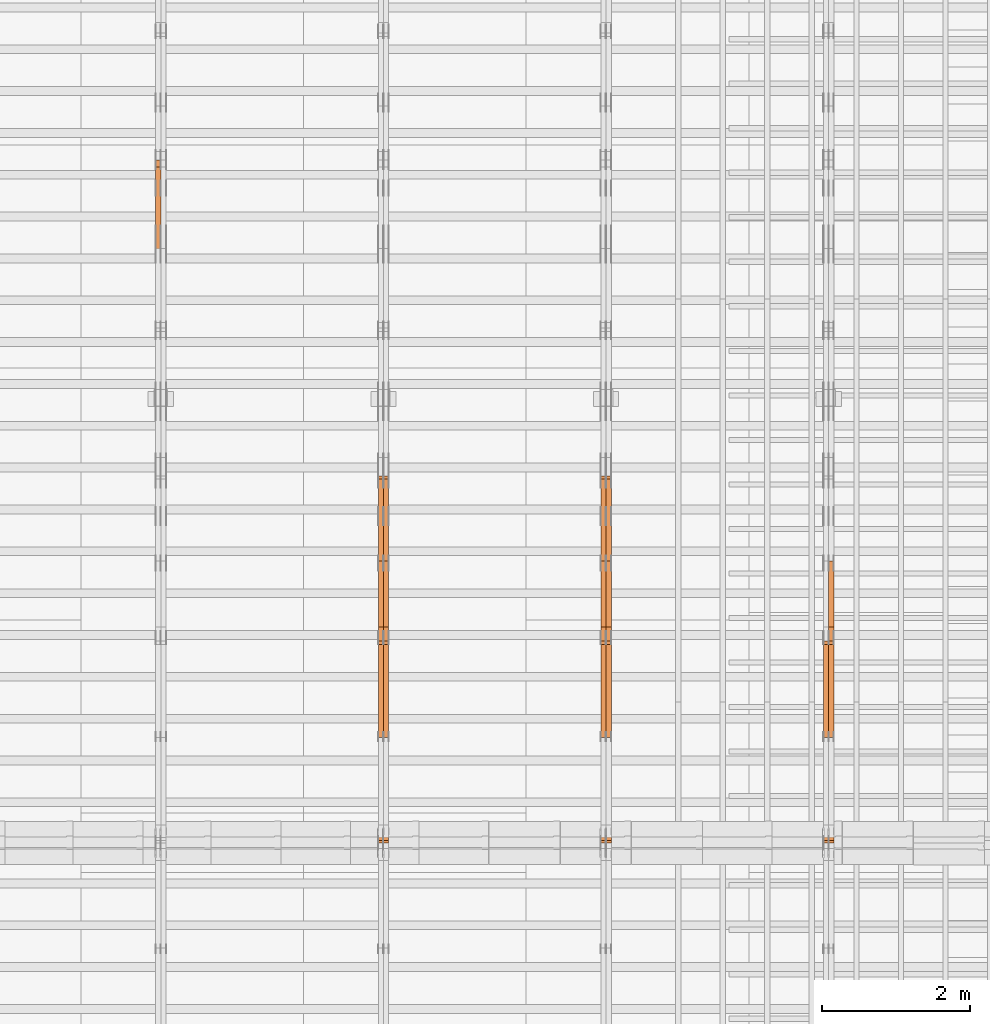
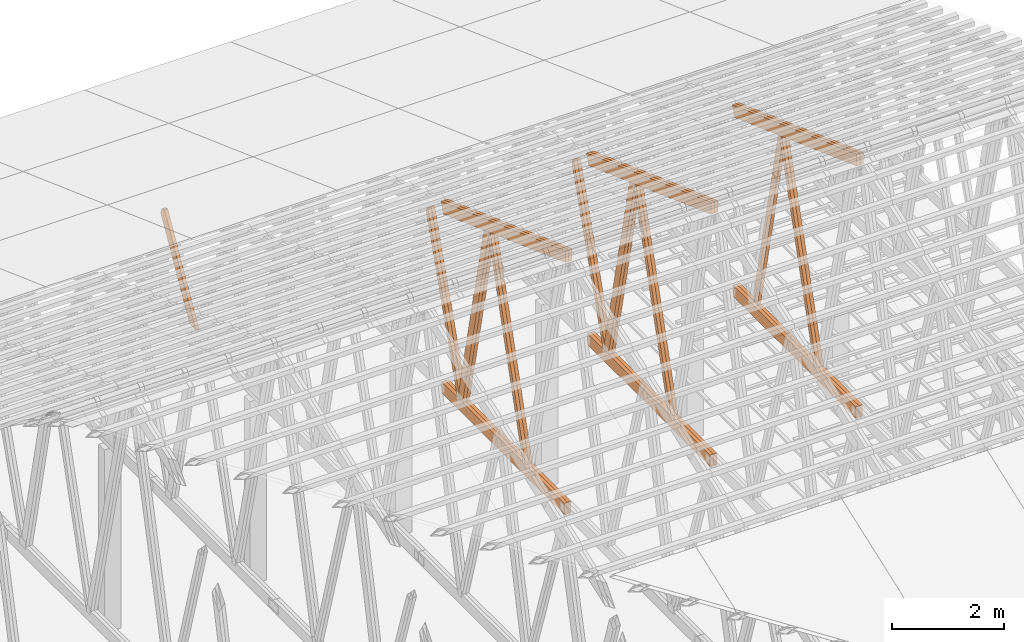
# One storey, part 59 of 189: 28 proxies.
"""IFC2X3 building model written with IfcOpenShell, lengths in millimetres."""

from ifc_helpers import new_model, entity, si_unit, converted_unit, derived_unit, direction, frame, origin, origin_2d_with_axis, place, context, subcontext, project, spatial, polyline, rectangle, outline, extrude, source, transform, mapped, material, type_object, type_shapes, element, save


model = new_model("IFC2X3")

# Units and contexts
model_context = context("Model", 3, precision=0.01, world=origin(), true_north=direction((6.12303176911189e-17, 1.0)))
body_context = subcontext(model_context, "Body", "Model", "MODEL_VIEW")
ifc_project = project(units=[si_unit("LENGTHUNIT", "METRE", prefix="MILLI"), si_unit("AREAUNIT", "SQUARE_METRE"), si_unit("VOLUMEUNIT", "CUBIC_METRE"), converted_unit("PLANEANGLEUNIT", "DEGREE", entity("IfcRatioMeasure", 0.0174532925199433), si_unit("PLANEANGLEUNIT", "RADIAN"), dimensions=[0, 0, 0, 0, 0, 0, 0]), si_unit("MASSUNIT", "GRAM", prefix="KILO"), derived_unit("MASSDENSITYUNIT", [(si_unit("MASSUNIT", "GRAM", prefix="KILO"), 1), (si_unit("LENGTHUNIT", "METRE"), -3)]), si_unit("TIMEUNIT", "SECOND"), si_unit("FREQUENCYUNIT", "HERTZ"), si_unit("THERMODYNAMICTEMPERATUREUNIT", "DEGREE_CELSIUS"), derived_unit("THERMALTRANSMITTANCEUNIT", [(si_unit("MASSUNIT", "GRAM", prefix="KILO"), 1), (si_unit("THERMODYNAMICTEMPERATUREUNIT", "KELVIN"), -1), (si_unit("TIMEUNIT", "SECOND"), -3)]), derived_unit("VOLUMETRICFLOWRATEUNIT", [(si_unit("LENGTHUNIT", "METRE"), 3), (si_unit("TIMEUNIT", "SECOND"), -1)]), si_unit("ELECTRICCURRENTUNIT", "AMPERE"), si_unit("ELECTRICVOLTAGEUNIT", "VOLT"), si_unit("POWERUNIT", "WATT"), si_unit("FORCEUNIT", "NEWTON"), si_unit("ILLUMINANCEUNIT", "LUX"), si_unit("LUMINOUSFLUXUNIT", "LUMEN"), si_unit("LUMINOUSINTENSITYUNIT", "CANDELA"), derived_unit("USERDEFINED", [(si_unit("MASSUNIT", "GRAM", prefix="KILO"), -1), (si_unit("LENGTHUNIT", "METRE"), -2), (si_unit("TIMEUNIT", "SECOND"), 3), (si_unit("LUMINOUSFLUXUNIT", "LUMEN"), 1)]), derived_unit("LINEARVELOCITYUNIT", [(si_unit("LENGTHUNIT", "METRE"), 1), (si_unit("TIMEUNIT", "SECOND"), -1)]), si_unit("PRESSUREUNIT", "PASCAL"), derived_unit("USERDEFINED", [(si_unit("LENGTHUNIT", "METRE"), -2), (si_unit("MASSUNIT", "GRAM", prefix="KILO"), 1), (si_unit("TIMEUNIT", "SECOND"), -2)])], contexts=[model_context])

# Site, building, storey
site_placement = place(None, origin())
site = spatial("IfcSite", under=ifc_project, at=site_placement, CompositionType="ELEMENT")
building_placement = place(site_placement, origin())
building = spatial("IfcBuilding", under=site, at=building_placement, CompositionType="ELEMENT")
storey_placement = place(building_placement, origin())
storey = spatial("IfcBuildingStorey", under=building, at=storey_placement, Name="Default", CompositionType="ELEMENT", Elevation=0.0)

# Proxies
ifc_material_1 = material(Name="IfcSurfaceStyle #241928")
building_element_proxy_type_1 = type_object("IfcBuildingElementProxyType", Name="T1-W6 241926", PredefinedType="NOTDEFINED", material=ifc_material_1)
shared_shape_1 = source(origin(), body_context, "Body", "SweptSolid", [
    extrude(outline(polyline([(-2668.68989660745, -47.5002238228721), (1800.72567700045, -47.5002238228721), (1797.68490303083, 0.000158637170537834), (1711.12272493628, 47.5001445042868), (-2640.84340836012, 47.5001445042868), (-2668.68989660745, -47.5002238228721)])), frame((1800.7257704503, 47.5001445042868, 0.0), z_axis=(0.0, 0.0, 1.0), x_axis=(-1.0, 0.0, 0.0)), (0.0, 0.0, 1.0), 69.9999999999997),
])
type_shapes(building_element_proxy_type_1, [shared_shape_1])
proxy_1_placement = place(building_placement, frame((45300.0, 17516.8749791841, 4507.23620831254), z_axis=(-1.0, 0.0, 0.0), x_axis=(0.0, -0.281285983104611, -0.959623986626466)))
element("IfcBuildingElementProxy", 1, at=proxy_1_placement, inside=storey, type_object=building_element_proxy_type_1, material=ifc_material_1, Name="T1-W6", context=body_context, shape_type="MappedRepresentation", body=[
    mapped(shared_shape_1, transform((0.0, 0.0, 0.0), scale=1.0)),
])
ifc_material_2 = material(Name="IfcSurfaceStyle #241862")
building_element_proxy_type_2 = type_object("IfcBuildingElementProxyType", Name="T1-W6 241860", PredefinedType="NOTDEFINED", material=ifc_material_2)
shared_shape_2 = source(origin(), body_context, "Body", "SweptSolid", [
    extrude(outline(polyline([(-2668.68989660745, -47.5002238228721), (1800.72567700045, -47.5002238228721), (1797.68490303083, 0.000158637170537834), (1711.12272493628, 47.5001445042868), (-2640.84340836012, 47.5001445042868), (-2668.68989660745, -47.5002238228721)])), frame((1800.7257704503, 47.5001445042868, 0.0), z_axis=(0.0, 0.0, 1.0), x_axis=(-1.0, 0.0, 0.0)), (0.0, 0.0, 1.0), 69.9999999999997),
])
type_shapes(building_element_proxy_type_2, [shared_shape_2])
proxy_2_placement = place(building_placement, frame((45230.0, 17516.8749791841, 4507.23620831254), z_axis=(-1.0, 0.0, 0.0), x_axis=(0.0, -0.281285983104611, -0.959623986626466)))
element("IfcBuildingElementProxy", 2, at=proxy_2_placement, inside=storey, type_object=building_element_proxy_type_2, material=ifc_material_2, Name="T1-W6", context=body_context, shape_type="MappedRepresentation", body=[
    mapped(shared_shape_2, transform((0.0, 0.0, 0.0), scale=1.0)),
])
ifc_material_3 = material(Name="IfcSurfaceStyle #241664")
building_element_proxy_type_3 = type_object("IfcBuildingElementProxyType", Name="T1-W3 241662", PredefinedType="NOTDEFINED", material=ifc_material_3)
shared_shape_3 = source(origin(), body_context, "Body", "SweptSolid", [
    extrude(outline(polyline([(-2517.58938959787, -85.0001104675026), (1625.445846867, -85.0001104675027), (1768.20563426494, 0.000209440697654673), (1749.48871563991, 85.0000057471538), (-2625.55080717397, 85.0000057471538), (-2517.58938959787, -85.0001104675026)])), frame((1768.2056683344, 85.0000547211315, 0.0), z_axis=(0.0, 0.0, 1.0), x_axis=(-1.0, 0.0, 0.0)), (0.0, 0.0, 1.0), 69.9999999999997),
])
type_shapes(building_element_proxy_type_3, [shared_shape_3])
proxy_3_placement = place(building_placement, frame((45300.0, 18415.3042863408, 226.720947016584), z_axis=(-1.0, 0.0, 0.0), x_axis=(0.0, -0.215047682154604, 0.976603550269982)))
element("IfcBuildingElementProxy", 3, at=proxy_3_placement, inside=storey, type_object=building_element_proxy_type_3, material=ifc_material_3, Name="T1-W3", context=body_context, shape_type="MappedRepresentation", body=[
    mapped(shared_shape_3, transform((0.0, 0.0, 0.0), scale=1.0)),
])
ifc_material_4 = material(Name="IfcSurfaceStyle #238154")
building_element_proxy_type_4 = type_object("IfcBuildingElementProxyType", Name="T1-B5 238152", PredefinedType="NOTDEFINED", material=ifc_material_4)
shared_shape_4 = source(origin(), body_context, "Body", "SweptSolid", [
    extrude(rectangle(XDim=4381.5, YDim=245.000000000001, at=origin_2d_with_axis()), frame((2190.75, 122.5, 0.0), z_axis=(0.0, 0.0, 1.0), x_axis=(-1.0, 0.0, 0.0)), (0.0, 0.0, 1.0), 69.9999999999997),
])
type_shapes(building_element_proxy_type_4, [shared_shape_4])
proxy_4_placement = place(building_placement, frame((45300.0, 14780.2587890625, 245.0), z_axis=(-1.0, 0.0, 0.0), x_axis=(0.0, 1.0, 0.0)))
element("IfcBuildingElementProxy", 4, at=proxy_4_placement, inside=storey, type_object=building_element_proxy_type_4, material=ifc_material_4, Name="T1-B5", context=body_context, shape_type="MappedRepresentation", body=[
    mapped(shared_shape_4, transform((0.0, 0.0, 0.0), scale=1.0)),
])
ifc_material_5 = material(Name="IfcSurfaceStyle #238097")
building_element_proxy_type_5 = type_object("IfcBuildingElementProxyType", Name="T1-B5 238095", PredefinedType="NOTDEFINED", material=ifc_material_5)
shared_shape_5 = source(origin(), body_context, "Body", "SweptSolid", [
    extrude(rectangle(XDim=4381.5, YDim=245.000000000001, at=origin_2d_with_axis()), frame((2190.75, 122.5, 0.0), z_axis=(0.0, 0.0, 1.0), x_axis=(-1.0, 0.0, 0.0)), (0.0, 0.0, 1.0), 69.9999999999997),
])
type_shapes(building_element_proxy_type_5, [shared_shape_5])
proxy_5_placement = place(building_placement, frame((45230.0, 14780.2587890625, 245.0), z_axis=(-1.0, 0.0, 0.0), x_axis=(0.0, 1.0, 0.0)))
element("IfcBuildingElementProxy", 5, at=proxy_5_placement, inside=storey, type_object=building_element_proxy_type_5, material=ifc_material_5, Name="T1-B5", context=body_context, shape_type="MappedRepresentation", body=[
    mapped(shared_shape_5, transform((0.0, 0.0, 0.0), scale=1.0)),
])
ifc_material_6 = material(Name="IfcSurfaceStyle #237338")
building_element_proxy_type_6 = type_object("IfcBuildingElementProxyType", Name="T1-T3 237336", PredefinedType="NOTDEFINED", material=ifc_material_6)
shared_shape_6 = source(origin(), body_context, "Body", "SweptSolid", [
    extrude(outline(polyline([(-2386.23525922045, -122.500022994835), (2341.64890001386, -122.500022994835), (2341.64888416412, 122.500022994835), (-2297.06252495753, 122.500022994835), (-2386.23525922045, -122.500022994835)])), frame((2341.64890001386, 122.500051926629, 0.0), z_axis=(0.0, 0.0, 1.0), x_axis=(-1.0, 0.0, 0.0)), (0.0, 0.0, 1.0), 69.9999999999997),
])
type_shapes(building_element_proxy_type_6, [shared_shape_6])
proxy_6_placement = place(building_placement, frame((45300.0, 19108.9628956236, 3921.30465489208), z_axis=(-1.0, 0.0, 0.0), x_axis=(0.0, -0.939692620785908, 0.342020143325669)))
element("IfcBuildingElementProxy", 6, at=proxy_6_placement, inside=storey, type_object=building_element_proxy_type_6, material=ifc_material_6, Name="T1-T3", context=body_context, shape_type="MappedRepresentation", body=[
    mapped(shared_shape_6, transform((0.0, 0.0, 0.0), scale=1.0)),
])
ifc_material_7 = material(Name="IfcSurfaceStyle #237281")
building_element_proxy_type_7 = type_object("IfcBuildingElementProxyType", Name="T1-T3 237279", PredefinedType="NOTDEFINED", material=ifc_material_7)
shared_shape_7 = source(origin(), body_context, "Body", "SweptSolid", [
    extrude(outline(polyline([(-2386.23525922045, -122.500022994835), (2341.64890001386, -122.500022994835), (2341.64888416412, 122.500022994835), (-2297.06252495753, 122.500022994835), (-2386.23525922045, -122.500022994835)])), frame((2341.64890001386, 122.500051926629, 0.0), z_axis=(0.0, 0.0, 1.0), x_axis=(-1.0, 0.0, 0.0)), (0.0, 0.0, 1.0), 69.9999999999997),
])
type_shapes(building_element_proxy_type_7, [shared_shape_7])
proxy_7_placement = place(building_placement, frame((45230.0, 19108.9628956236, 3921.30465489208), z_axis=(-1.0, 0.0, 0.0), x_axis=(0.0, -0.939692620785908, 0.342020143325669)))
element("IfcBuildingElementProxy", 7, at=proxy_7_placement, inside=storey, type_object=building_element_proxy_type_7, material=ifc_material_7, Name="T1-T3", context=body_context, shape_type="MappedRepresentation", body=[
    mapped(shared_shape_7, transform((0.0, 0.0, 0.0), scale=1.0)),
])
ifc_material_8 = material(Name="IfcSurfaceStyle #226138")
building_element_proxy_type_8 = type_object("IfcBuildingElementProxyType", Name="T1-W6 226136", PredefinedType="NOTDEFINED", material=ifc_material_8)
shared_shape_8 = source(origin(), body_context, "Body", "SweptSolid", [
    extrude(outline(polyline([(-2668.68989660745, -47.5002238228721), (1800.72567700045, -47.5002238228721), (1797.68490303083, 0.000158637170537834), (1711.12272493628, 47.5001445042868), (-2640.84340836012, 47.5001445042868), (-2668.68989660745, -47.5002238228721)])), frame((1800.7257704503, 47.5001445042868, 0.0), z_axis=(0.0, 0.0, 1.0), x_axis=(-1.0, 0.0, 0.0)), (0.0, 0.0, 1.0), 69.9999999999997),
])
type_shapes(building_element_proxy_type_8, [shared_shape_8])
proxy_8_placement = place(building_placement, frame((42300.0, 17516.8749791841, 4507.23620831254), z_axis=(-1.0, 0.0, 0.0), x_axis=(0.0, -0.281285983104611, -0.959623986626466)))
element("IfcBuildingElementProxy", 8, at=proxy_8_placement, inside=storey, type_object=building_element_proxy_type_8, material=ifc_material_8, Name="T1-W6", context=body_context, shape_type="MappedRepresentation", body=[
    mapped(shared_shape_8, transform((0.0, 0.0, 0.0), scale=1.0)),
])
ifc_material_9 = material(Name="IfcSurfaceStyle #226072")
building_element_proxy_type_9 = type_object("IfcBuildingElementProxyType", Name="T1-W6 226070", PredefinedType="NOTDEFINED", material=ifc_material_9)
shared_shape_9 = source(origin(), body_context, "Body", "SweptSolid", [
    extrude(outline(polyline([(-2668.68989660745, -47.5002238228721), (1800.72567700045, -47.5002238228721), (1797.68490303083, 0.000158637170537834), (1711.12272493628, 47.5001445042868), (-2640.84340836012, 47.5001445042868), (-2668.68989660745, -47.5002238228721)])), frame((1800.7257704503, 47.5001445042868, 0.0), z_axis=(0.0, 0.0, 1.0), x_axis=(-1.0, 0.0, 0.0)), (0.0, 0.0, 1.0), 69.9999999999997),
])
type_shapes(building_element_proxy_type_9, [shared_shape_9])
proxy_9_placement = place(building_placement, frame((42230.0, 17516.8749791841, 4507.23620831254), z_axis=(-1.0, 0.0, 0.0), x_axis=(0.0, -0.281285983104611, -0.959623986626466)))
element("IfcBuildingElementProxy", 9, at=proxy_9_placement, inside=storey, type_object=building_element_proxy_type_9, material=ifc_material_9, Name="T1-W6", context=body_context, shape_type="MappedRepresentation", body=[
    mapped(shared_shape_9, transform((0.0, 0.0, 0.0), scale=1.0)),
])
ifc_material_10 = material(Name="IfcSurfaceStyle #225874")
building_element_proxy_type_10 = type_object("IfcBuildingElementProxyType", Name="T1-W3 225872", PredefinedType="NOTDEFINED", material=ifc_material_10)
shared_shape_10 = source(origin(), body_context, "Body", "SweptSolid", [
    extrude(outline(polyline([(-2517.58938959787, -85.0001104675026), (1625.445846867, -85.0001104675027), (1768.20563426494, 0.000209440697654673), (1749.48871563991, 85.0000057471538), (-2625.55080717397, 85.0000057471538), (-2517.58938959787, -85.0001104675026)])), frame((1768.2056683344, 85.0000547211315, 0.0), z_axis=(0.0, 0.0, 1.0), x_axis=(-1.0, 0.0, 0.0)), (0.0, 0.0, 1.0), 69.9999999999997),
])
type_shapes(building_element_proxy_type_10, [shared_shape_10])
proxy_10_placement = place(building_placement, frame((42300.0, 18415.3042863408, 226.720947016584), z_axis=(-1.0, 0.0, 0.0), x_axis=(0.0, -0.215047682154604, 0.976603550269982)))
element("IfcBuildingElementProxy", 10, at=proxy_10_placement, inside=storey, type_object=building_element_proxy_type_10, material=ifc_material_10, Name="T1-W3", context=body_context, shape_type="MappedRepresentation", body=[
    mapped(shared_shape_10, transform((0.0, 0.0, 0.0), scale=1.0)),
])
ifc_material_11 = material(Name="IfcSurfaceStyle #225808")
building_element_proxy_type_11 = type_object("IfcBuildingElementProxyType", Name="T1-W3 225806", PredefinedType="NOTDEFINED", material=ifc_material_11)
shared_shape_11 = source(origin(), body_context, "Body", "SweptSolid", [
    extrude(outline(polyline([(-2517.58938959787, -85.0001104675026), (1625.445846867, -85.0001104675027), (1768.20563426494, 0.000209440697654673), (1749.48871563991, 85.0000057471538), (-2625.55080717397, 85.0000057471538), (-2517.58938959787, -85.0001104675026)])), frame((1768.2056683344, 85.0000547211315, 0.0), z_axis=(0.0, 0.0, 1.0), x_axis=(-1.0, 0.0, 0.0)), (0.0, 0.0, 1.0), 69.9999999999997),
])
type_shapes(building_element_proxy_type_11, [shared_shape_11])
proxy_11_placement = place(building_placement, frame((42230.0, 18415.3042863408, 226.720947016584), z_axis=(-1.0, 0.0, 0.0), x_axis=(0.0, -0.215047682154604, 0.976603550269982)))
element("IfcBuildingElementProxy", 11, at=proxy_11_placement, inside=storey, type_object=building_element_proxy_type_11, material=ifc_material_11, Name="T1-W3", context=body_context, shape_type="MappedRepresentation", body=[
    mapped(shared_shape_11, transform((0.0, 0.0, 0.0), scale=1.0)),
])
ifc_material_12 = material(Name="IfcSurfaceStyle #225610")
building_element_proxy_type_12 = type_object("IfcBuildingElementProxyType", Name="T1-W7 225608", PredefinedType="NOTDEFINED", material=ifc_material_12)
shared_shape_12 = source(origin(), body_context, "Body", "SweptSolid", [
    extrude(outline(polyline([(-2189.6662270939, -47.5000140805343), (1475.30081553583, -47.5000140805343), (1473.93388518462, 0.00042343352179337), (1398.58463533215, 47.4998023637734), (-2158.15310895869, 47.4998023637734), (-2189.6662270939, -47.5000140805343)])), frame((1475.30081553583, 47.5004895824757, 0.0), z_axis=(0.0, 0.0, 1.0), x_axis=(-1.0, 0.0, 0.0)), (0.0, 0.0, 1.0), 69.9999999999998),
])
type_shapes(building_element_proxy_type_12, [shared_shape_12])
proxy_12_placement = place(building_placement, frame((42300.0, 19742.3819153401, 3693.66743808885), z_axis=(-1.0, 0.0, 0.0), x_axis=(0.0, -0.314845237923104, -0.949143021971475)))
element("IfcBuildingElementProxy", 12, at=proxy_12_placement, inside=storey, type_object=building_element_proxy_type_12, material=ifc_material_12, Name="T1-W7", context=body_context, shape_type="MappedRepresentation", body=[
    mapped(shared_shape_12, transform((0.0, 0.0, 0.0), scale=1.0)),
])
ifc_material_13 = material(Name="IfcSurfaceStyle #225544")
building_element_proxy_type_13 = type_object("IfcBuildingElementProxyType", Name="T1-W7 225542", PredefinedType="NOTDEFINED", material=ifc_material_13)
shared_shape_13 = source(origin(), body_context, "Body", "SweptSolid", [
    extrude(outline(polyline([(-2189.6662270939, -47.5000140805343), (1475.30081553583, -47.5000140805343), (1473.93388518462, 0.00042343352179337), (1398.58463533215, 47.4998023637734), (-2158.15310895869, 47.4998023637734), (-2189.6662270939, -47.5000140805343)])), frame((1475.30081553583, 47.5004895824757, 0.0), z_axis=(0.0, 0.0, 1.0), x_axis=(-1.0, 0.0, 0.0)), (0.0, 0.0, 1.0), 69.9999999999998),
])
type_shapes(building_element_proxy_type_13, [shared_shape_13])
proxy_13_placement = place(building_placement, frame((42230.0, 19742.3819153401, 3693.66743808885), z_axis=(-1.0, 0.0, 0.0), x_axis=(0.0, -0.314845237923104, -0.949143021971475)))
element("IfcBuildingElementProxy", 13, at=proxy_13_placement, inside=storey, type_object=building_element_proxy_type_13, material=ifc_material_13, Name="T1-W7", context=body_context, shape_type="MappedRepresentation", body=[
    mapped(shared_shape_13, transform((0.0, 0.0, 0.0), scale=1.0)),
])
ifc_material_14 = material(Name="IfcSurfaceStyle #222364")
building_element_proxy_type_14 = type_object("IfcBuildingElementProxyType", Name="T1-B5 222362", PredefinedType="NOTDEFINED", material=ifc_material_14)
shared_shape_14 = source(origin(), body_context, "Body", "SweptSolid", [
    extrude(rectangle(XDim=4381.5, YDim=245.000000000001, at=origin_2d_with_axis()), frame((2190.75, 122.5, 0.0), z_axis=(0.0, 0.0, 1.0), x_axis=(-1.0, 0.0, 0.0)), (0.0, 0.0, 1.0), 69.9999999999997),
])
type_shapes(building_element_proxy_type_14, [shared_shape_14])
proxy_14_placement = place(building_placement, frame((42300.0, 14780.2587890625, 245.0), z_axis=(-1.0, 0.0, 0.0), x_axis=(0.0, 1.0, 0.0)))
element("IfcBuildingElementProxy", 14, at=proxy_14_placement, inside=storey, type_object=building_element_proxy_type_14, material=ifc_material_14, Name="T1-B5", context=body_context, shape_type="MappedRepresentation", body=[
    mapped(shared_shape_14, transform((0.0, 0.0, 0.0), scale=1.0)),
])
ifc_material_15 = material(Name="IfcSurfaceStyle #222307")
building_element_proxy_type_15 = type_object("IfcBuildingElementProxyType", Name="T1-B5 222305", PredefinedType="NOTDEFINED", material=ifc_material_15)
shared_shape_15 = source(origin(), body_context, "Body", "SweptSolid", [
    extrude(rectangle(XDim=4381.5, YDim=245.000000000001, at=origin_2d_with_axis()), frame((2190.75, 122.5, 0.0), z_axis=(0.0, 0.0, 1.0), x_axis=(-1.0, 0.0, 0.0)), (0.0, 0.0, 1.0), 69.9999999999997),
])
type_shapes(building_element_proxy_type_15, [shared_shape_15])
proxy_15_placement = place(building_placement, frame((42230.0, 14780.2587890625, 245.0), z_axis=(-1.0, 0.0, 0.0), x_axis=(0.0, 1.0, 0.0)))
element("IfcBuildingElementProxy", 15, at=proxy_15_placement, inside=storey, type_object=building_element_proxy_type_15, material=ifc_material_15, Name="T1-B5", context=body_context, shape_type="MappedRepresentation", body=[
    mapped(shared_shape_15, transform((0.0, 0.0, 0.0), scale=1.0)),
])
ifc_material_16 = material(Name="IfcSurfaceStyle #221548")
building_element_proxy_type_16 = type_object("IfcBuildingElementProxyType", Name="T1-T3 221546", PredefinedType="NOTDEFINED", material=ifc_material_16)
shared_shape_16 = source(origin(), body_context, "Body", "SweptSolid", [
    extrude(outline(polyline([(-2386.23525922045, -122.500022994835), (2341.64890001386, -122.500022994835), (2341.64888416412, 122.500022994835), (-2297.06252495753, 122.500022994835), (-2386.23525922045, -122.500022994835)])), frame((2341.64890001386, 122.500051926629, 0.0), z_axis=(0.0, 0.0, 1.0), x_axis=(-1.0, 0.0, 0.0)), (0.0, 0.0, 1.0), 69.9999999999997),
])
type_shapes(building_element_proxy_type_16, [shared_shape_16])
proxy_16_placement = place(building_placement, frame((42300.0, 19108.9628956236, 3921.30465489208), z_axis=(-1.0, 0.0, 0.0), x_axis=(0.0, -0.939692620785908, 0.342020143325669)))
element("IfcBuildingElementProxy", 16, at=proxy_16_placement, inside=storey, type_object=building_element_proxy_type_16, material=ifc_material_16, Name="T1-T3", context=body_context, shape_type="MappedRepresentation", body=[
    mapped(shared_shape_16, transform((0.0, 0.0, 0.0), scale=1.0)),
])
ifc_material_17 = material(Name="IfcSurfaceStyle #221491")
building_element_proxy_type_17 = type_object("IfcBuildingElementProxyType", Name="T1-T3 221489", PredefinedType="NOTDEFINED", material=ifc_material_17)
shared_shape_17 = source(origin(), body_context, "Body", "SweptSolid", [
    extrude(outline(polyline([(-2386.23525922045, -122.500022994835), (2341.64890001386, -122.500022994835), (2341.64888416412, 122.500022994835), (-2297.06252495753, 122.500022994835), (-2386.23525922045, -122.500022994835)])), frame((2341.64890001386, 122.500051926629, 0.0), z_axis=(0.0, 0.0, 1.0), x_axis=(-1.0, 0.0, 0.0)), (0.0, 0.0, 1.0), 69.9999999999997),
])
type_shapes(building_element_proxy_type_17, [shared_shape_17])
proxy_17_placement = place(building_placement, frame((42230.0, 19108.9628956236, 3921.30465489208), z_axis=(-1.0, 0.0, 0.0), x_axis=(0.0, -0.939692620785908, 0.342020143325669)))
element("IfcBuildingElementProxy", 17, at=proxy_17_placement, inside=storey, type_object=building_element_proxy_type_17, material=ifc_material_17, Name="T1-T3", context=body_context, shape_type="MappedRepresentation", body=[
    mapped(shared_shape_17, transform((0.0, 0.0, 0.0), scale=1.0)),
])
ifc_material_18 = material(Name="IfcSurfaceStyle #210348")
building_element_proxy_type_18 = type_object("IfcBuildingElementProxyType", Name="T1-W6 210346", PredefinedType="NOTDEFINED", material=ifc_material_18)
shared_shape_18 = source(origin(), body_context, "Body", "SweptSolid", [
    extrude(outline(polyline([(-2668.68989660745, -47.5002238228721), (1800.72567700045, -47.5002238228721), (1797.68490303083, 0.000158637170537834), (1711.12272493628, 47.5001445042868), (-2640.84340836012, 47.5001445042868), (-2668.68989660745, -47.5002238228721)])), frame((1800.7257704503, 47.5001445042868, 0.0), z_axis=(0.0, 0.0, 1.0), x_axis=(-1.0, 0.0, 0.0)), (0.0, 0.0, 1.0), 69.9999999999997),
])
type_shapes(building_element_proxy_type_18, [shared_shape_18])
proxy_18_placement = place(building_placement, frame((39300.0, 17516.8749791841, 4507.23620831254), z_axis=(-1.0, 0.0, 0.0), x_axis=(0.0, -0.281285983104611, -0.959623986626466)))
element("IfcBuildingElementProxy", 18, at=proxy_18_placement, inside=storey, type_object=building_element_proxy_type_18, material=ifc_material_18, Name="T1-W6", context=body_context, shape_type="MappedRepresentation", body=[
    mapped(shared_shape_18, transform((0.0, 0.0, 0.0), scale=1.0)),
])
ifc_material_19 = material(Name="IfcSurfaceStyle #210282")
building_element_proxy_type_19 = type_object("IfcBuildingElementProxyType", Name="T1-W6 210280", PredefinedType="NOTDEFINED", material=ifc_material_19)
shared_shape_19 = source(origin(), body_context, "Body", "SweptSolid", [
    extrude(outline(polyline([(-2668.68989660745, -47.5002238228721), (1800.72567700045, -47.5002238228721), (1797.68490303083, 0.000158637170537834), (1711.12272493628, 47.5001445042868), (-2640.84340836012, 47.5001445042868), (-2668.68989660745, -47.5002238228721)])), frame((1800.7257704503, 47.5001445042868, 0.0), z_axis=(0.0, 0.0, 1.0), x_axis=(-1.0, 0.0, 0.0)), (0.0, 0.0, 1.0), 69.9999999999997),
])
type_shapes(building_element_proxy_type_19, [shared_shape_19])
proxy_19_placement = place(building_placement, frame((39230.0, 17516.8749791841, 4507.23620831254), z_axis=(-1.0, 0.0, 0.0), x_axis=(0.0, -0.281285983104611, -0.959623986626466)))
element("IfcBuildingElementProxy", 19, at=proxy_19_placement, inside=storey, type_object=building_element_proxy_type_19, material=ifc_material_19, Name="T1-W6", context=body_context, shape_type="MappedRepresentation", body=[
    mapped(shared_shape_19, transform((0.0, 0.0, 0.0), scale=1.0)),
])
ifc_material_20 = material(Name="IfcSurfaceStyle #210084")
building_element_proxy_type_20 = type_object("IfcBuildingElementProxyType", Name="T1-W3 210082", PredefinedType="NOTDEFINED", material=ifc_material_20)
shared_shape_20 = source(origin(), body_context, "Body", "SweptSolid", [
    extrude(outline(polyline([(-2517.58938959787, -85.0001104675026), (1625.445846867, -85.0001104675027), (1768.20563426494, 0.000209440697654673), (1749.48871563991, 85.0000057471538), (-2625.55080717397, 85.0000057471538), (-2517.58938959787, -85.0001104675026)])), frame((1768.2056683344, 85.0000547211315, 0.0), z_axis=(0.0, 0.0, 1.0), x_axis=(-1.0, 0.0, 0.0)), (0.0, 0.0, 1.0), 69.9999999999997),
])
type_shapes(building_element_proxy_type_20, [shared_shape_20])
proxy_20_placement = place(building_placement, frame((39300.0, 18415.3042863408, 226.720947016584), z_axis=(-1.0, 0.0, 0.0), x_axis=(0.0, -0.215047682154604, 0.976603550269982)))
element("IfcBuildingElementProxy", 20, at=proxy_20_placement, inside=storey, type_object=building_element_proxy_type_20, material=ifc_material_20, Name="T1-W3", context=body_context, shape_type="MappedRepresentation", body=[
    mapped(shared_shape_20, transform((0.0, 0.0, 0.0), scale=1.0)),
])
ifc_material_21 = material(Name="IfcSurfaceStyle #210018")
building_element_proxy_type_21 = type_object("IfcBuildingElementProxyType", Name="T1-W3 210016", PredefinedType="NOTDEFINED", material=ifc_material_21)
shared_shape_21 = source(origin(), body_context, "Body", "SweptSolid", [
    extrude(outline(polyline([(-2517.58938959787, -85.0001104675026), (1625.445846867, -85.0001104675027), (1768.20563426494, 0.000209440697654673), (1749.48871563991, 85.0000057471538), (-2625.55080717397, 85.0000057471538), (-2517.58938959787, -85.0001104675026)])), frame((1768.2056683344, 85.0000547211315, 0.0), z_axis=(0.0, 0.0, 1.0), x_axis=(-1.0, 0.0, 0.0)), (0.0, 0.0, 1.0), 69.9999999999997),
])
type_shapes(building_element_proxy_type_21, [shared_shape_21])
proxy_21_placement = place(building_placement, frame((39230.0, 18415.3042863408, 226.720947016584), z_axis=(-1.0, 0.0, 0.0), x_axis=(0.0, -0.215047682154604, 0.976603550269982)))
element("IfcBuildingElementProxy", 21, at=proxy_21_placement, inside=storey, type_object=building_element_proxy_type_21, material=ifc_material_21, Name="T1-W3", context=body_context, shape_type="MappedRepresentation", body=[
    mapped(shared_shape_21, transform((0.0, 0.0, 0.0), scale=1.0)),
])
ifc_material_22 = material(Name="IfcSurfaceStyle #209820")
building_element_proxy_type_22 = type_object("IfcBuildingElementProxyType", Name="T1-W7 209818", PredefinedType="NOTDEFINED", material=ifc_material_22)
shared_shape_22 = source(origin(), body_context, "Body", "SweptSolid", [
    extrude(outline(polyline([(-2189.6662270939, -47.5000140805343), (1475.30081553583, -47.5000140805343), (1473.93388518462, 0.00042343352179337), (1398.58463533215, 47.4998023637734), (-2158.15310895869, 47.4998023637734), (-2189.6662270939, -47.5000140805343)])), frame((1475.30081553583, 47.5004895824757, 0.0), z_axis=(0.0, 0.0, 1.0), x_axis=(-1.0, 0.0, 0.0)), (0.0, 0.0, 1.0), 69.9999999999998),
])
type_shapes(building_element_proxy_type_22, [shared_shape_22])
proxy_22_placement = place(building_placement, frame((39300.0, 19742.3819153401, 3693.66743808885), z_axis=(-1.0, 0.0, 0.0), x_axis=(0.0, -0.314845237923104, -0.949143021971475)))
element("IfcBuildingElementProxy", 22, at=proxy_22_placement, inside=storey, type_object=building_element_proxy_type_22, material=ifc_material_22, Name="T1-W7", context=body_context, shape_type="MappedRepresentation", body=[
    mapped(shared_shape_22, transform((0.0, 0.0, 0.0), scale=1.0)),
])
ifc_material_23 = material(Name="IfcSurfaceStyle #209754")
building_element_proxy_type_23 = type_object("IfcBuildingElementProxyType", Name="T1-W7 209752", PredefinedType="NOTDEFINED", material=ifc_material_23)
shared_shape_23 = source(origin(), body_context, "Body", "SweptSolid", [
    extrude(outline(polyline([(-2189.6662270939, -47.5000140805343), (1475.30081553583, -47.5000140805343), (1473.93388518462, 0.00042343352179337), (1398.58463533215, 47.4998023637734), (-2158.15310895869, 47.4998023637734), (-2189.6662270939, -47.5000140805343)])), frame((1475.30081553583, 47.5004895824757, 0.0), z_axis=(0.0, 0.0, 1.0), x_axis=(-1.0, 0.0, 0.0)), (0.0, 0.0, 1.0), 69.9999999999998),
])
type_shapes(building_element_proxy_type_23, [shared_shape_23])
proxy_23_placement = place(building_placement, frame((39230.0, 19742.3819153401, 3693.66743808885), z_axis=(-1.0, 0.0, 0.0), x_axis=(0.0, -0.314845237923104, -0.949143021971475)))
element("IfcBuildingElementProxy", 23, at=proxy_23_placement, inside=storey, type_object=building_element_proxy_type_23, material=ifc_material_23, Name="T1-W7", context=body_context, shape_type="MappedRepresentation", body=[
    mapped(shared_shape_23, transform((0.0, 0.0, 0.0), scale=1.0)),
])
ifc_material_24 = material(Name="IfcSurfaceStyle #206574")
building_element_proxy_type_24 = type_object("IfcBuildingElementProxyType", Name="T1-B5 206572", PredefinedType="NOTDEFINED", material=ifc_material_24)
shared_shape_24 = source(origin(), body_context, "Body", "SweptSolid", [
    extrude(rectangle(XDim=4381.5, YDim=245.000000000001, at=origin_2d_with_axis()), frame((2190.75, 122.5, 0.0), z_axis=(0.0, 0.0, 1.0), x_axis=(-1.0, 0.0, 0.0)), (0.0, 0.0, 1.0), 69.9999999999997),
])
type_shapes(building_element_proxy_type_24, [shared_shape_24])
proxy_24_placement = place(building_placement, frame((39300.0, 14780.2587890625, 245.0), z_axis=(-1.0, 0.0, 0.0), x_axis=(0.0, 1.0, 0.0)))
element("IfcBuildingElementProxy", 24, at=proxy_24_placement, inside=storey, type_object=building_element_proxy_type_24, material=ifc_material_24, Name="T1-B5", context=body_context, shape_type="MappedRepresentation", body=[
    mapped(shared_shape_24, transform((0.0, 0.0, 0.0), scale=1.0)),
])
ifc_material_25 = material(Name="IfcSurfaceStyle #206517")
building_element_proxy_type_25 = type_object("IfcBuildingElementProxyType", Name="T1-B5 206515", PredefinedType="NOTDEFINED", material=ifc_material_25)
shared_shape_25 = source(origin(), body_context, "Body", "SweptSolid", [
    extrude(rectangle(XDim=4381.5, YDim=245.000000000001, at=origin_2d_with_axis()), frame((2190.75, 122.5, 0.0), z_axis=(0.0, 0.0, 1.0), x_axis=(-1.0, 0.0, 0.0)), (0.0, 0.0, 1.0), 69.9999999999997),
])
type_shapes(building_element_proxy_type_25, [shared_shape_25])
proxy_25_placement = place(building_placement, frame((39230.0, 14780.2587890625, 245.0), z_axis=(-1.0, 0.0, 0.0), x_axis=(0.0, 1.0, 0.0)))
element("IfcBuildingElementProxy", 25, at=proxy_25_placement, inside=storey, type_object=building_element_proxy_type_25, material=ifc_material_25, Name="T1-B5", context=body_context, shape_type="MappedRepresentation", body=[
    mapped(shared_shape_25, transform((0.0, 0.0, 0.0), scale=1.0)),
])
ifc_material_26 = material(Name="IfcSurfaceStyle #205758")
building_element_proxy_type_26 = type_object("IfcBuildingElementProxyType", Name="T1-T3 205756", PredefinedType="NOTDEFINED", material=ifc_material_26)
shared_shape_26 = source(origin(), body_context, "Body", "SweptSolid", [
    extrude(outline(polyline([(-2386.23525922045, -122.500022994835), (2341.64890001386, -122.500022994835), (2341.64888416412, 122.500022994835), (-2297.06252495753, 122.500022994835), (-2386.23525922045, -122.500022994835)])), frame((2341.64890001386, 122.500051926629, 0.0), z_axis=(0.0, 0.0, 1.0), x_axis=(-1.0, 0.0, 0.0)), (0.0, 0.0, 1.0), 69.9999999999997),
])
type_shapes(building_element_proxy_type_26, [shared_shape_26])
proxy_26_placement = place(building_placement, frame((39300.0, 19108.9628956236, 3921.30465489208), z_axis=(-1.0, 0.0, 0.0), x_axis=(0.0, -0.939692620785908, 0.342020143325669)))
element("IfcBuildingElementProxy", 26, at=proxy_26_placement, inside=storey, type_object=building_element_proxy_type_26, material=ifc_material_26, Name="T1-T3", context=body_context, shape_type="MappedRepresentation", body=[
    mapped(shared_shape_26, transform((0.0, 0.0, 0.0), scale=1.0)),
])
ifc_material_27 = material(Name="IfcSurfaceStyle #205701")
building_element_proxy_type_27 = type_object("IfcBuildingElementProxyType", Name="T1-T3 205699", PredefinedType="NOTDEFINED", material=ifc_material_27)
shared_shape_27 = source(origin(), body_context, "Body", "SweptSolid", [
    extrude(outline(polyline([(-2386.23525922045, -122.500022994835), (2341.64890001386, -122.500022994835), (2341.64888416412, 122.500022994835), (-2297.06252495753, 122.500022994835), (-2386.23525922045, -122.500022994835)])), frame((2341.64890001386, 122.500051926629, 0.0), z_axis=(0.0, 0.0, 1.0), x_axis=(-1.0, 0.0, 0.0)), (0.0, 0.0, 1.0), 69.9999999999997),
])
type_shapes(building_element_proxy_type_27, [shared_shape_27])
proxy_27_placement = place(building_placement, frame((39230.0, 19108.9628956236, 3921.30465489208), z_axis=(-1.0, 0.0, 0.0), x_axis=(0.0, -0.939692620785908, 0.342020143325669)))
element("IfcBuildingElementProxy", 27, at=proxy_27_placement, inside=storey, type_object=building_element_proxy_type_27, material=ifc_material_27, Name="T1-T3", context=body_context, shape_type="MappedRepresentation", body=[
    mapped(shared_shape_27, transform((0.0, 0.0, 0.0), scale=1.0)),
])
ifc_material_28 = material(Name="IfcSurfaceStyle #192908")
building_element_proxy_type_28 = type_object("IfcBuildingElementProxyType", Name="T1-W2 192906", PredefinedType="NOTDEFINED", material=ifc_material_28)
shared_shape_28 = source(origin(), body_context, "Body", "SweptSolid", [
    extrude(outline(polyline([(-1361.89144606429, -97.5000598486876), (887.613245225805, -97.5000598486876), (904.774262962339, 0.000302345139042259), (818.892339969004, 97.4999086761182), (-1249.38840209286, 97.4999086761182), (-1361.89144606429, -97.5000598486876)])), frame((904.774262962339, 97.5000966763391, 0.0), z_axis=(0.0, 0.0, 1.0), x_axis=(-1.0, 0.0, 0.0)), (0.0, 0.0, 1.0), 69.9999999999999),
])
type_shapes(building_element_proxy_type_28, [shared_shape_28])
proxy_28_placement = place(building_placement, frame((36230.0, 24033.6159173732, 2110.89189244614), z_axis=(-1.0, 0.0, 0.0), x_axis=(0.0, -0.5, -0.866025403784439)))
element("IfcBuildingElementProxy", 28, at=proxy_28_placement, inside=storey, type_object=building_element_proxy_type_28, material=ifc_material_28, Name="T1-W2", context=body_context, shape_type="MappedRepresentation", body=[
    mapped(shared_shape_28, transform((0.0, 0.0, 0.0), scale=1.0)),
])

save(model, "model.ifc")
